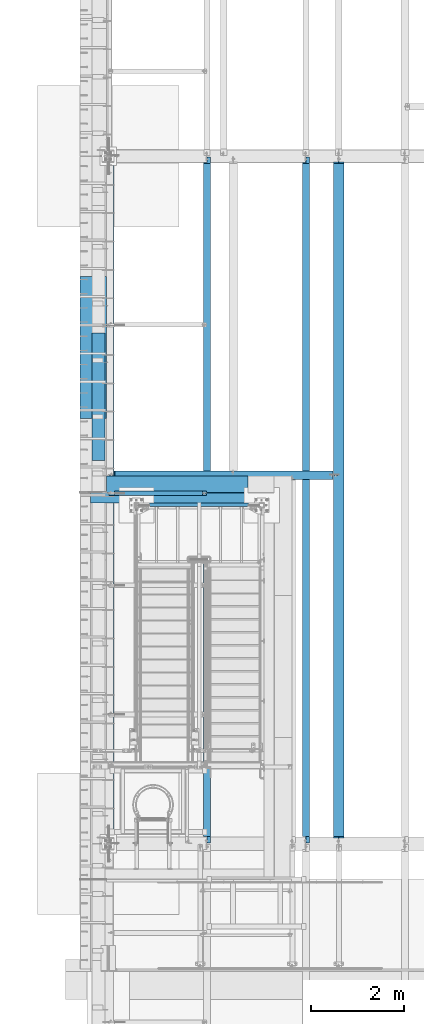
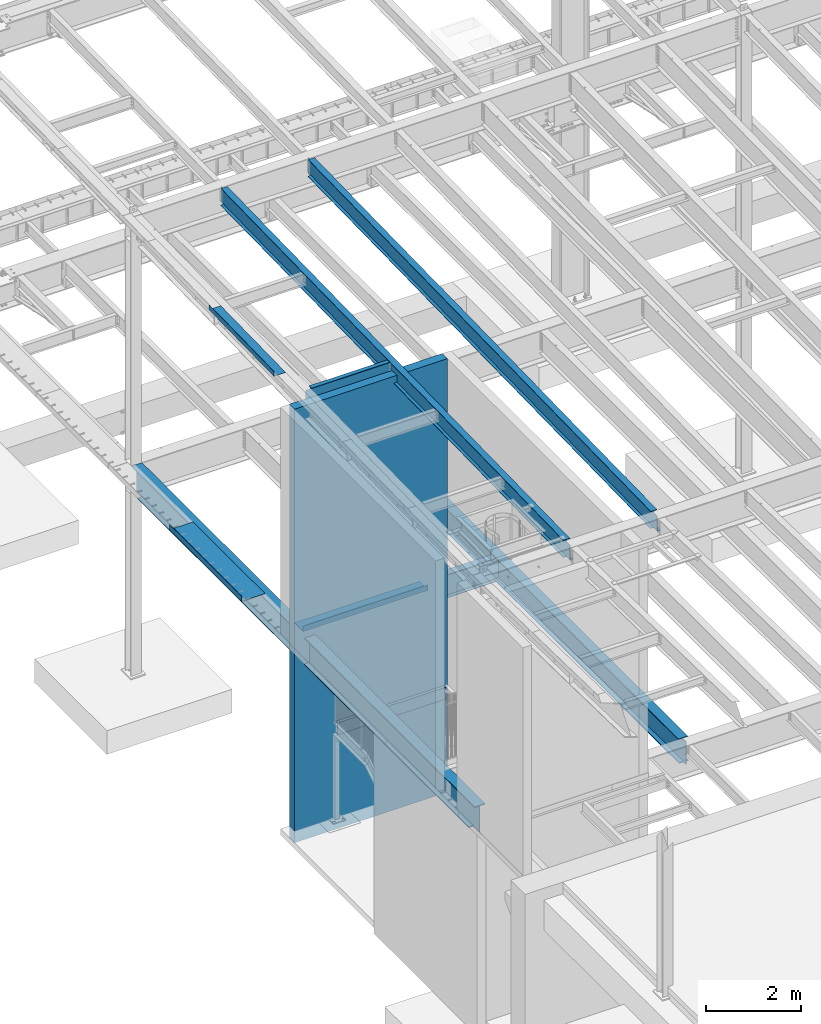
# One storey, part 1095 of 1763: 11 beams, 9 elements without a shape of their own.
"""IFC2X3 building model written with IfcOpenShell, lengths in millimetres."""

from ifc_helpers import new_model, si_unit, frame, origin_with_axes, place, context, subcontext, project, spatial, faceted_brep, material, type_object, element, aggregate, save


model = new_model("IFC2X3")

# Units and contexts
model_context = context("Model", 3, precision=1e-05, world=origin_with_axes())
body_context = subcontext(model_context, "Body", "Model", "MODEL_VIEW")
ifc_project = project(units=[si_unit("LENGTHUNIT", "METRE", prefix="MILLI"), si_unit("AREAUNIT", "SQUARE_METRE"), si_unit("VOLUMEUNIT", "CUBIC_METRE"), si_unit("MASSUNIT", "GRAM", prefix="KILO"), si_unit("TIMEUNIT", "SECOND"), si_unit("PLANEANGLEUNIT", "RADIAN"), si_unit("SOLIDANGLEUNIT", "STERADIAN"), si_unit("THERMODYNAMICTEMPERATUREUNIT", "DEGREE_CELSIUS"), si_unit("LUMINOUSINTENSITYUNIT", "LUMEN")], contexts=[model_context])

# Site, building, storey
site_placement = place(None, origin_with_axes())
site = spatial("IfcSite", under=ifc_project, at=site_placement, CompositionType="ELEMENT")
building_placement = place(site_placement, origin_with_axes())
building = spatial("IfcBuilding", under=site, at=building_placement, Name="Undefined", CompositionType="ELEMENT")
storey_placement = place(building_placement, origin_with_axes())
storey = spatial("IfcBuildingStorey", under=building, at=storey_placement, Name="Undefined", CompositionType="ELEMENT", Elevation=0.0)

# Assembly, beam
assembly_1_placement = place(storey_placement, origin_with_axes())
assembly_1 = element("IfcElementAssembly", 1, at=assembly_1_placement, inside=storey, Name="STRINGER", AssemblyPlace="NOTDEFINED", PredefinedType="RIGID_FRAME")
ifc_material_1 = material(Name="STEEL/A36")
beam_type_1 = type_object("IfcBeamType", Name="C12X20.7", PredefinedType="NOTDEFINED")
beam_1_placement = place(assembly_1_placement, frame((-84098.8372737317, 37312.6, 2630.48750002433), z_axis=(0.0, 0.0, 1.0), x_axis=(-1.0, 0.0, 0.0)))
beam_1 = element("IfcBeam", 2, at=beam_1_placement, type_object=beam_type_1, material=ifc_material_1, Name="STRINGER", ObjectType="C12X20.7", context=body_context, shape_type="Brep", body=[
    faceted_brep([(0.0, 38.1000000000004, -152.4), (0.0, 38.1000000000004, 152.4), (2641.60000000367, 38.0999999999985, 152.4), (2641.60000000367, 38.0999999999985, -152.4), (0.0, -38.1000000000004, 152.4), (2641.60000000367, -38.0999999999985, 152.4), (0.0, -38.1000000000004, 146.04746), (2641.60000000367, -38.0999999999985, 146.04746), (0.0, 30.1625000000004, 134.6749275), (2641.60000000367, 30.1624999999985, 134.6749275), (0.0, 30.1625000000004, -134.6749275), (2641.60000000367, 30.1624999999985, -134.6749275), (0.0, -38.1000000000004, -146.04746), (2641.60000000367, -38.0999999999985, -146.04746), (0.0, -38.1000000000004, -152.4), (2641.60000000367, -38.0999999999985, -152.4)], [[[0, 1, 2, 3]], [[1, 4, 5, 2]], [[4, 6, 7, 5]], [[6, 8, 9, 7]], [[8, 10, 11, 9]], [[10, 12, 13, 11]], [[12, 14, 15, 13]], [[14, 0, 3, 15]], [[5, 7, 9, 11, 13, 15, 3, 2]], [[14, 12, 10, 8, 6, 4, 1, 0]]]),
])
aggregate(assembly_1, [beam_1])

assembly_2_placement = place(storey_placement, origin_with_axes())
assembly_2 = element("IfcElementAssembly", 3, at=assembly_2_placement, inside=storey, Name="BEAM", AssemblyPlace="NOTDEFINED", PredefinedType="RIGID_FRAME")
beam_type_2 = type_object("IfcBeamType", PredefinedType="NOTDEFINED")
beam_2_placement = place(assembly_2_placement, frame((-85888.7435236983, 37934.9, 5199.0625), z_axis=(-1.0, 0.0, 0.0), x_axis=(0.0, -1.0, 0.0)))
beam_2 = element("IfcBeam", 4, at=beam_2_placement, type_object=beam_type_2, material=ifc_material_1, Name="BENT_PLATE", context=body_context, shape_type="Brep", body=[
    faceted_brep([(0.0, -4.76249999999982, -1524.0), (0.0, -4.76249999999982, 1524.0), (0.0, 4.76249999999982, 1524.0), (0.0, 4.76249999999982, -1524.0), (358.774987792975, 4.76249999999982, 1524.0), (358.774987792975, 4.76249999999982, -1524.0), (368.299987792969, -4.76249999999982, -1524.0), (368.299987792969, -4.76249999999982, 1524.0), (358.774987792975, 134.937496948242, 1524.0), (358.774987792975, 134.937496948242, -1524.0), (368.299987792969, 134.937496948242, 1524.0), (368.299987792969, 134.937496948242, -1524.0)], [[[0, 1, 2, 3]], [[3, 2, 4, 5]], [[1, 0, 6, 7]], [[5, 4, 8, 9]], [[4, 2, 1, 7, 10, 8]], [[7, 6, 11, 10]], [[6, 0, 3, 5, 9, 11]], [[10, 11, 9, 8]]]),
])

assembly_3_placement = place(storey_placement, origin_with_axes())
assembly_3 = element("IfcElementAssembly", 5, at=assembly_3_placement, inside=storey, Name="BEAM", AssemblyPlace="NOTDEFINED", PredefinedType="RIGID_FRAME")
beam_type_3 = type_object("IfcBeamType", PredefinedType="NOTDEFINED")
beam_3_placement = place(assembly_3_placement, frame((-87413.5372736984, 40693.9755, 5199.0625), z_axis=(0.0, -1.0, 0.0), x_axis=(-1.0, 0.0, 0.0)))
beam_3 = element("IfcBeam", 6, at=beam_3_placement, type_object=beam_type_3, material=ifc_material_1, Name="BENT_PLATE", context=body_context, shape_type="Brep", body=[
    faceted_brep([(0.0, -4.76249999999982, -1524.0), (0.0, -4.76249999999982, 1524.0), (0.0, 4.76249999999982, 1524.0), (0.0, 4.76249999999982, -1524.0), (571.5, 4.76249999999982, 1524.0), (571.5, 4.76249999999982, -1524.0), (561.975000000006, -4.76249999999982, -1524.0), (561.975000000006, -4.76249999999982, 1524.0), (571.5, -134.937496948242, 1524.0), (571.5, -134.937496948242, -1524.0), (561.975000000006, -134.937496948242, 1524.0), (561.975000000006, -134.937496948242, -1524.0)], [[[0, 1, 2, 3]], [[3, 2, 4, 5]], [[1, 0, 6, 7]], [[5, 4, 8, 9]], [[4, 2, 1, 7, 10, 8]], [[7, 6, 11, 10]], [[6, 0, 3, 5, 9, 11]], [[10, 11, 9, 8]]]),
])

assembly_4_placement = place(storey_placement, origin_with_axes())
assembly_4 = element("IfcElementAssembly", 7, at=assembly_4_placement, inside=storey, Name="BEAM", AssemblyPlace="NOTDEFINED", PredefinedType="RIGID_FRAME")
beam_type_4 = type_object("IfcBeamType", PredefinedType="NOTDEFINED")
beam_4_placement = place(assembly_4_placement, frame((-87438.9372736983, 39629.9999848266, 11492.2453307455), z_axis=(0.0, -0.999786037781472, -0.0206852279954809), x_axis=(-1.0, 0.0, 0.0)))
beam_4 = element("IfcBeam", 8, at=beam_4_placement, type_object=beam_type_4, material=ifc_material_1, Name="BENT_PLATE", context=body_context, shape_type="Brep", body=[
    faceted_brep([(2.91038304567337e-11, -3.17499999963729, -1371.60000000396), (-2.91038304567337e-11, -3.17500000036489, 1371.60000000395), (-2.91038304567337e-11, 3.17499999963184, 1371.60000000395), (2.91038304567337e-11, 3.17500000035943, -1371.60000000396), (285.75000000016, 3.17499999930078, 1371.59999999897), (285.750000000276, 3.17499999982283, -1371.59999999897), (279.400000000271, -3.1750000001648, -1371.59999999897), (279.400000000154, -3.17500000068321, 1371.59999999897), (285.750000000218, -123.824997298658, 1371.59999999895), (285.750000000218, -123.824997298212, -1371.59999999898), (279.400000000212, -123.824997298658, 1371.59999999895), (279.400000000212, -123.824997298212, -1371.59999999898)], [[[0, 1, 2, 3]], [[3, 2, 4, 5]], [[1, 0, 6, 7]], [[5, 4, 8, 9]], [[4, 2, 1, 7, 10, 8]], [[7, 6, 11, 10]], [[6, 0, 3, 5, 9, 11]], [[10, 11, 9, 8]]]),
])
aggregate(assembly_4, [beam_4])

assembly_5_placement = place(storey_placement, origin_with_axes())
assembly_5 = element("IfcElementAssembly", 9, at=assembly_5_placement, inside=storey, Name="BEAM", AssemblyPlace="NOTDEFINED", PredefinedType="RIGID_FRAME")
ifc_material_2 = material(Name="STEEL/A992")
beam_type_5 = type_object("IfcBeamType", Name="W18X35", PredefinedType="NOTDEFINED")
beam_5_placement = place(assembly_5_placement, frame((-83122.7515594126, 30027.4629676506, 11064.9232324289), z_axis=(0.0, -0.0206852279954837, 0.999786037781472), x_axis=(0.0, 0.999786037781472, 0.0206852279954825)))
beam_5 = element("IfcBeam", 10, at=beam_5_placement, type_object=beam_type_5, material=ifc_material_2, Name="BEAM", ObjectType="W18X35", context=body_context, shape_type="Brep", body=[
    faceted_brep([(161.234036217043, 4.26867060289806, -214.312499999869), (161.234036217025, 4.26882632687921, -225.424999999863), (10.5200655540102, 4.26881607816904, -225.424999999832), (10.7499793429743, 4.26866036980209, -214.312499999842), (161.234031325755, 76.1999999999971, -214.312499999867), (161.234031325748, 76.1999999999971, -225.424999999861), (161.234031013333, -3.96875, 180.714997672841), (161.234031013333, 3.96875, 180.714997672841), (160.267301090749, 3.96875, 175.854918154808), (160.267301090749, -3.96875, 175.854918154808), (157.514287190275, 3.96875, 171.734741686663), (157.514287190275, -3.96875, 171.734741686663), (153.394110722133, 3.96875, 168.981727786193), (153.394110722133, -3.96875, 168.981727786193), (148.534031204097, 3.96875, 168.014997863607), (148.534031204097, -3.96875, 168.014997863607), (18.6602033211384, 3.96875, 168.014997863631), (18.6602033211384, -3.96875, 168.014997863631), (10.7499793429743, -3.96875, -214.312499999842), (14757.8115434472, -3.96875, -214.312500002648), (14765.8531467846, -3.96875, 174.36500163611), (14641.5955948759, -3.96875, 174.365001636133), (14636.7355153579, -3.96875, 175.331731558719), (14632.6153388897, -3.96875, 178.084745459191), (14629.8623249892, -3.96875, 182.204921927336), (14628.8955950666, -3.96875, 187.065001445368), (14628.8955950666, -3.96875, 214.312499997053), (161.234030986467, -3.96875, 214.312499999809), (10.7499793429743, -76.1999999999971, -214.312499999842), (14757.8115434472, -76.1999999999971, -214.312500002648), (10.5200655540102, -76.1999999999971, -225.424999999832), (14757.5816296582, -76.1999999999971, -225.425000002639), (14641.5955921487, 4.26882640406257, -214.312500002627), (14641.5955921487, 4.26867068048159, -225.425000002617), (14641.5955830855, 76.1999999999971, -225.425000002617), (14641.5955830855, 76.1999999999971, -214.312500002628), (14757.8115434472, 4.26884104704368, -214.312500002648), (14757.5816296582, 4.26868529446074, -225.425000002639), (14757.8115434472, 3.96875, -214.312500002648), (14765.8531467846, 3.96875, 174.36500163611), (14641.5955948759, 3.96875, 174.365001636133), (14636.7355153579, 3.96875, 175.331731558719), (14632.6153388897, 3.96875, 178.084745459191), (14629.8623249892, 3.96875, 182.204921927336), (14628.8955950666, 3.96875, 187.065001445368), (14628.8955950666, -76.1999999999971, 225.424999997045), (14628.8955950666, -76.1999999999971, 214.312499997053), (14628.8955950666, 3.96875, 214.312499997053), (14628.8955950666, 76.1999999999971, 214.312499997053), (14628.8955950666, 76.1999999999971, 225.424999997045), (161.234030986467, 3.96875, 214.312499999809), (161.234030986467, 76.1999999999971, 214.312499999809), (161.23403098647, 76.1999999999971, 225.424999999799), (161.23403098647, -76.1999999999971, 225.424999999799), (161.234030986467, -76.1999999999971, 214.312499999809), (10.7499793429743, 3.96875, -214.312499999842)], [[[0, 1, 2, 3]], [[4, 5, 1, 0]], [[6, 7, 8, 9]], [[9, 8, 10, 11]], [[11, 10, 12, 13]], [[13, 12, 14, 15]], [[15, 14, 16, 17]], [[9, 11, 13, 15, 17, 18, 19, 20, 21, 22, 23, 24, 25, 26, 27, 6]], [[18, 28, 29, 19]], [[28, 30, 31, 29]], [[32, 33, 34, 35]], [[36, 37, 33, 32]], [[38, 39, 20, 19, 29, 31, 37, 36]], [[20, 39, 40, 21]], [[21, 40, 41, 22]], [[22, 41, 42, 23]], [[23, 42, 43, 24]], [[24, 43, 44, 25]], [[45, 46, 26, 25, 44, 47, 48, 49]], [[48, 47, 50, 51]], [[49, 48, 51, 52]], [[45, 49, 52, 53]], [[46, 45, 53, 54]], [[26, 46, 54, 27]], [[53, 52, 51, 50, 7, 6, 27, 54]], [[47, 44, 43, 42, 41, 40, 39, 38, 55, 16, 14, 12, 10, 8, 7, 50]], [[30, 28, 18, 17, 16, 55, 3, 2]], [[34, 33, 37, 31, 30, 2, 1, 5]], [[35, 34, 5, 4]], [[55, 38, 36, 32, 35, 4, 0, 3]]]),
])
aggregate(assembly_5, [beam_5])

assembly_6_placement = place(storey_placement, origin_with_axes())
assembly_6 = element("IfcElementAssembly", 11, at=assembly_6_placement, inside=storey, Name="BEAM", AssemblyPlace="NOTDEFINED", PredefinedType="RIGID_FRAME")
beam_6_placement = place(assembly_6_placement, frame((-85249.0944165555, 30027.4629676506, 11064.9232324289), z_axis=(0.0, -0.0206852279954837, 0.999786037781472), x_axis=(0.0, 0.999786037781472, 0.0206852279954825)))
beam_6 = element("IfcBeam", 12, at=beam_6_placement, type_object=beam_type_5, material=ifc_material_2, Name="BEAM", ObjectType="W18X35", context=body_context, shape_type="Brep", body=[
    faceted_brep([(161.234036217043, 4.26867060289806, -214.312499999869), (161.234036217025, 4.26882632687921, -225.424999999863), (10.5200655540102, 4.26881607816904, -225.424999999832), (10.7499793429743, 4.26866036980209, -214.312499999842), (161.234031325755, 76.1999999999971, -214.312499999867), (161.234031325748, 76.1999999999971, -225.424999999861), (161.234031013333, -3.96875, 180.714997672841), (161.234031013333, 3.96875, 180.714997672841), (160.267301090749, 3.96875, 175.854918154808), (160.267301090749, -3.96875, 175.854918154808), (157.514287190275, 3.96875, 171.734741686663), (157.514287190275, -3.96875, 171.734741686663), (153.394110722133, 3.96875, 168.981727786193), (153.394110722133, -3.96875, 168.981727786193), (148.534031204097, 3.96875, 168.014997863607), (148.534031204097, -3.96875, 168.014997863607), (18.6602033211384, 3.96875, 168.014997863631), (18.6602033211384, -3.96875, 168.014997863631), (10.7499793429743, -3.96875, -214.312499999842), (14757.8115434472, -3.96875, -214.312500002648), (14765.8531467846, -3.96875, 174.36500163611), (14641.5955948759, -3.96875, 174.365001636133), (14636.7355153579, -3.96875, 175.331731558719), (14632.6153388897, -3.96875, 178.084745459191), (14629.8623249892, -3.96875, 182.204921927336), (14628.8955950666, -3.96875, 187.065001445368), (14628.8955950666, -3.96875, 214.312499997053), (161.234030986467, -3.96875, 214.312499999809), (10.7499793429743, -76.1999999999971, -214.312499999842), (14757.8115434472, -76.1999999999971, -214.312500002648), (10.5200655540102, -76.1999999999971, -225.424999999832), (14757.5816296582, -76.1999999999971, -225.425000002639), (14641.5955921487, 4.26882640406257, -214.312500002627), (14641.5955921487, 4.26867068048159, -225.425000002617), (14641.5955830855, 76.1999999999971, -225.425000002617), (14641.5955830855, 76.1999999999971, -214.312500002628), (14757.8115434472, 4.26884104704368, -214.312500002648), (14757.5816296582, 4.26868529446074, -225.425000002639), (14757.8115434472, 3.96875, -214.312500002648), (14765.8531467846, 3.96875, 174.36500163611), (14641.5955948759, 3.96875, 174.365001636133), (14636.7355153579, 3.96875, 175.331731558719), (14632.6153388897, 3.96875, 178.084745459191), (14629.8623249892, 3.96875, 182.204921927336), (14628.8955950666, 3.96875, 187.065001445368), (14628.8955950666, -76.1999999999971, 225.424999997045), (14628.8955950666, -76.1999999999971, 214.312499997053), (14628.8955950666, 3.96875, 214.312499997053), (14628.8955950666, 76.1999999999971, 214.312499997053), (14628.8955950666, 76.1999999999971, 225.424999997045), (161.234030986467, 3.96875, 214.312499999809), (161.234030986467, 76.1999999999971, 214.312499999809), (161.23403098647, 76.1999999999971, 225.424999999799), (161.23403098647, -76.1999999999971, 225.424999999799), (161.234030986467, -76.1999999999971, 214.312499999809), (10.7499793429743, 3.96875, -214.312499999842)], [[[0, 1, 2, 3]], [[4, 5, 1, 0]], [[6, 7, 8, 9]], [[9, 8, 10, 11]], [[11, 10, 12, 13]], [[13, 12, 14, 15]], [[15, 14, 16, 17]], [[9, 11, 13, 15, 17, 18, 19, 20, 21, 22, 23, 24, 25, 26, 27, 6]], [[18, 28, 29, 19]], [[28, 30, 31, 29]], [[32, 33, 34, 35]], [[36, 37, 33, 32]], [[38, 39, 20, 19, 29, 31, 37, 36]], [[20, 39, 40, 21]], [[21, 40, 41, 22]], [[22, 41, 42, 23]], [[23, 42, 43, 24]], [[24, 43, 44, 25]], [[45, 46, 26, 25, 44, 47, 48, 49]], [[48, 47, 50, 51]], [[49, 48, 51, 52]], [[45, 49, 52, 53]], [[46, 45, 53, 54]], [[26, 46, 54, 27]], [[53, 52, 51, 50, 7, 6, 27, 54]], [[47, 44, 43, 42, 41, 40, 39, 38, 55, 16, 14, 12, 10, 8, 7, 50]], [[30, 28, 18, 17, 16, 55, 3, 2]], [[34, 33, 37, 31, 30, 2, 1, 5]], [[35, 34, 5, 4]], [[55, 38, 36, 32, 35, 4, 0, 3]]]),
])
aggregate(assembly_6, [beam_6])

assembly_7_placement = place(storey_placement, origin_with_axes())
assembly_7 = element("IfcElementAssembly", 13, at=assembly_7_placement, inside=storey, Name="BEAM", AssemblyPlace="NOTDEFINED", PredefinedType="RIGID_FRAME")
beam_type_6 = type_object("IfcBeamType", Name="W12X22", PredefinedType="NOTDEFINED")
beam_7_placement = place(assembly_7_placement, frame((-87375.4372736983, 37560.25, 11290.6722385647), z_axis=(0.0, 0.0, 1.0), x_axis=(1.0, 0.0, 0.0)))
beam_7 = element("IfcBeam", 14, at=beam_7_placement, type_object=beam_type_6, material=ifc_material_2, Name="BEAM", ObjectType="W12X22", context=body_context, shape_type="Brep", body=[
    faceted_brep([(18.2562499999913, -3.17499999999927, -144.4625), (18.2562499999913, -50.7999999999993, -144.4625), (2109.67410714286, -50.7999999999993, -144.4625), (2109.67410714286, -3.17499999999927, -144.4625), (18.2562499999913, -50.7999999999993, -155.575000000001), (2109.67410714286, -50.7999999999993, -155.575000000001), (2109.67410714286, 3.17499999999927, -144.4625), (2109.67410714286, 50.7999999999993, -144.4625), (132.556249999994, 50.7999999999993, -144.4625), (132.556249999994, 3.17575008238782, -144.4625), (2033.47410714286, -50.7999999999993, 155.575000000001), (2033.47410714286, -50.7999999999993, 144.4625), (2033.47410714286, -3.17499999999927, 144.4625), (2033.47410714286, -3.17499999999927, 136.265001487105), (2033.47410714286, 3.17499999999927, 136.265001487105), (2033.47410714286, 3.17499999999927, 144.4625), (2033.47410714286, 50.7999999999993, 144.4625), (2033.47410714286, 50.7999999999993, 155.575000000001), (2034.44083706544, -3.17499999999927, 131.404921969059), (2034.44083706544, 3.17499999999927, 131.404921969059), (2037.19385096592, -3.17499999999927, 127.284745500905), (2037.19385096592, 3.17499999999927, 127.284745500905), (2041.31402743408, -3.17499999999927, 124.531731600428), (2041.31402743408, 3.17499999999927, 124.531731600428), (2046.17410695212, -3.17499999999927, 123.56500167784), (2046.17410695212, 3.17499999999927, 123.56500167784), (2109.67410714286, -3.17499999999927, 123.56500167784), (2109.67410714286, 3.17499999999927, 123.56500167784), (2109.67410714286, 50.7999999999993, -155.575000000001), (132.556249999994, 50.7999999999993, -155.575000000001), (132.556249999994, 3.17575008238782, -155.575000000001), (18.2562499999913, 3.17575008238782, -155.575000000001), (18.2562499999913, 3.17499999999927, -144.4625), (124.716329708754, -3.17499999999927, 105.741729925645), (124.716329708754, 3.17500736736474, 105.741729925645), (119.856250190714, 3.1750086254724, 104.775000003057), (119.856250190714, -3.17499999999927, 104.775000003057), (128.836506176915, -3.17499999999927, 108.494743826122), (128.836506176915, 3.17500378457771, 108.494743826122), (131.589520077396, -3.17499999999927, 112.614920294276), (131.589520077396, 3.17499842256075, 112.614920294276), (132.55624999998, -3.17499999999927, 117.474999812322), (132.55624999998, 3.17499209762536, 117.474999812322), (18.2562499999913, 3.17499999999927, -137.353076309833), (18.2562499999913, 3.17499999999927, 104.775000003057), (132.55624999998, 3.17499999999927, 144.4625), (132.55624999998, 50.7999999999993, 144.4625), (132.55624999998, 50.7999999999993, 155.575000000001), (132.55624999998, -50.7999999999993, 155.575000000001), (132.55624999998, -50.7999999999993, 144.4625), (132.55624999998, -3.17499999999927, 144.4625), (18.2562499999913, -3.17499999999927, 104.775000003057)], [[[0, 1, 2, 3]], [[1, 4, 5, 2]], [[6, 7, 8, 9]], [[10, 11, 12, 13, 14, 15, 16, 17]], [[18, 19, 14, 13]], [[20, 21, 19, 18]], [[22, 23, 21, 20]], [[24, 25, 23, 22]], [[26, 27, 25, 24]], [[3, 2, 5, 28, 7, 6, 27, 26]], [[7, 28, 29, 8]], [[8, 29, 30, 9]], [[28, 5, 4, 31, 30, 29]], [[9, 30, 31, 32]], [[33, 34, 35, 36]], [[37, 38, 34, 33]], [[39, 40, 38, 37]], [[41, 42, 40, 39]], [[15, 14, 19, 21, 23, 25, 27, 6, 9, 32, 43, 44, 35, 34, 38, 40, 42, 45]], [[16, 15, 45, 46]], [[17, 16, 46, 47]], [[10, 17, 47, 48]], [[11, 10, 48, 49]], [[12, 11, 49, 50]], [[48, 47, 46, 45, 42, 41, 50, 49]], [[39, 37, 33, 36, 51, 0, 3, 26, 24, 22, 20, 18, 13, 12, 50, 41]], [[43, 32, 31, 4, 1, 0, 51, 44]], [[36, 35, 44, 51]]]),
])
aggregate(assembly_7, [beam_7])

# Beam
beam_type_7 = type_object("IfcBeamType", Name="W24X55", PredefinedType="NOTDEFINED")
beam_8_placement = place(assembly_2_placement, frame((-87375.4372736983, 37947.6, 4894.2625), z_axis=(0.0, 0.0, 1.0), x_axis=(1.0, 0.0, 0.0)))
beam_8 = element("IfcBeam", 15, at=beam_8_placement, type_object=beam_type_7, material=ifc_material_2, Name="BEAM", ObjectType="W24X55", context=body_context, shape_type="Brep", body=[
    faceted_brep([(19.84375, -5.06289274062146, -287.3375), (19.84375, -5.06217950861901, -300.0375), (121.443785019117, -5.06214201812691, -300.0375), (121.443785019292, -5.06285525016574, -287.3375), (121.443815955325, -88.9000000000015, -287.3375), (121.443815955325, -88.9000000000015, -300.0375), (121.443751839222, 88.9000000000015, -300.0375), (121.443751839222, 88.9000000000015, -287.3375), (4834.46666666666, 88.9000000000015, -287.3375), (4834.46666666666, 88.9000000000015, -300.0375), (121.44378277479, 5.06285495873453, -300.0375), (121.443782774979, 5.0621417266957, -287.3375), (19.84375, 5.06281746905006, -300.0375), (19.84375, 5.06210423704761, -287.3375), (19.84375, 4.76249999999709, -287.3375), (4834.46666666666, 4.76249999999709, -287.3375), (4942.41666666666, -4.76249999999709, 268.027501678467), (4942.41666666666, 4.76249999999709, 268.027501678467), (4847.16666647593, 4.76249999999709, 268.027501678467), (4847.16666647593, -4.76249999999709, 268.027501678467), (4842.30658695789, 4.76249999999709, 268.994231601055), (4842.30658695789, -4.76249999999709, 268.994231601055), (4838.18641048972, 4.76249999999709, 271.747245501533), (4838.18641048972, -4.76249999999709, 271.747245501533), (4835.43339658924, 4.76249999999709, 275.867421969687), (4835.43339658924, -4.76249999999709, 275.867421969687), (4834.46666666666, 4.76249999999709, 280.727501487732), (4834.46666666666, -4.76249999999709, 280.727501487732), (4834.46666666666, -88.9000000000015, 300.0375), (4834.46666666666, -88.9000000000015, 287.3375), (4834.46666666666, -4.76249999999709, 287.3375), (4834.46666666666, 4.76249999999709, 287.3375), (4834.46666666666, 88.9000000000015, 287.3375), (4834.46666666666, 88.9000000000015, 300.0375), (146.843749999985, 4.76249999999709, 287.3375), (146.843749999985, 88.9000000000015, 287.3375), (146.843749999985, 88.9000000000015, 300.0375), (146.843749999985, -88.9000000000015, 300.0375), (146.843749999985, -88.9000000000015, 287.3375), (146.843749999985, -4.76249999999709, 287.3375), (146.843749999985, 4.76249999999709, 274.377501487732), (146.843749999985, -4.76249999999709, 274.377501487732), (145.877020077402, 4.76249999999709, 269.517421969686), (145.877020077402, -4.76249999999709, 269.517421969686), (143.12400617692, 4.76249999999709, 265.397245501533), (143.12400617692, -4.76249999999709, 265.397245501533), (139.003829708759, 4.76249999999709, 262.644231601054), (139.003829708759, -4.76249999999709, 262.644231601054), (134.14375019072, 4.76249999999709, 261.677501678467), (134.14375019072, -4.76249999999709, 261.677501678467), (19.84375, 4.76249999999709, 261.677501678467), (19.84375, -4.76249999999709, 261.677501678467), (19.84375, -4.76249999999709, -287.3375), (4834.46666666666, -4.76249999999709, -287.3375), (4834.46666666666, -4.76249999999709, -284.422499809265), (4835.43339658924, -4.76249999999709, -279.562420291219), (4838.18641048972, -4.76249999999709, -275.442243823066), (4842.30658695789, -4.76249999999709, -272.689229922587), (4847.16666647593, -4.76249999999709, -271.7225), (4942.41666666666, -4.76249999999709, -271.7225), (4942.41666666666, 4.76249999999709, -271.7225), (4842.30658695789, 4.76249999999709, -272.689229922587), (4838.18641048972, 4.76249999999709, -275.442243823066), (4835.43339658924, 4.76249999999709, -279.562420291219), (4834.46666666666, 4.76249999999709, -284.422499809265), (4847.16666647593, 4.76249999999709, -271.7225), (4834.46666666666, -88.9000000000015, -287.3375), (4834.46666666666, -88.9000000000015, -300.0375)], [[[0, 1, 2, 3]], [[4, 3, 2, 5]], [[6, 7, 8, 9]], [[7, 6, 10, 11]], [[11, 10, 12, 13]], [[7, 11, 13, 14, 15, 8]], [[16, 17, 18, 19]], [[19, 18, 20, 21]], [[21, 20, 22, 23]], [[23, 22, 24, 25]], [[25, 24, 26, 27]], [[28, 29, 30, 27, 26, 31, 32, 33]], [[32, 31, 34, 35]], [[33, 32, 35, 36]], [[28, 33, 36, 37]], [[29, 28, 37, 38]], [[30, 29, 38, 39]], [[37, 36, 35, 34, 40, 41, 39, 38]], [[41, 40, 42, 43]], [[43, 42, 44, 45]], [[45, 44, 46, 47]], [[47, 46, 48, 49]], [[49, 48, 50, 51]], [[16, 19, 21, 23, 25, 27, 30, 39, 41, 43, 45, 47, 49, 51, 52, 53, 54, 55, 56, 57, 58, 59]], [[17, 16, 59, 60]], [[61, 62, 63, 64, 15, 14, 50, 48, 46, 44, 42, 40, 34, 31, 26, 24, 22, 20, 18, 17, 60, 65]], [[59, 58, 65, 60]], [[57, 61, 65, 58]], [[56, 62, 61, 57]], [[55, 63, 62, 56]], [[54, 64, 63, 55]], [[53, 66, 67, 9, 8, 15, 64, 54]], [[67, 66, 4, 5]], [[1, 12, 10, 6, 9, 67, 5, 2]], [[52, 51, 50, 14, 13, 12, 1, 0]], [[66, 53, 52, 0, 3, 4]]]),
])

aggregate(assembly_2, [beam_2, beam_8])

# Assembly, beam
assembly_8_placement = place(storey_placement, origin_with_axes())
assembly_8 = element("IfcElementAssembly", 16, at=assembly_8_placement, inside=storey, Name="WALL", AssemblyPlace="NOTDEFINED", PredefinedType="REINFORCEMENT_UNIT")
ifc_material_3 = material(Name="CONCRETE/5000")
beam_type_8 = type_object("IfcBeamType", PredefinedType="NOTDEFINED")
beam_9_placement = place(assembly_8_placement, frame((-87750.0872736983, 37458.65, 5588.0), z_axis=(0.0, 1.0, 0.0), x_axis=(1.0, 0.0, 0.0)))
beam_9 = element("IfcBeam", 17, at=beam_9_placement, type_object=beam_type_8, material=ifc_material_3, Name="WALL", context=body_context, shape_type="Brep", body=[
    faceted_brep([(0.0, 5588.0, -107.949999999997), (0.0, 5588.0, 107.949999999997), (3727.45, 5588.0, 107.949999999997), (3727.45, 5588.0, -107.949999999997), (0.0, -5588.0, 107.949999999997), (3727.45, -5588.0, 107.949999999997), (0.0, -5588.0, -107.949999999997), (3727.45, -5588.0, -107.949999999997)], [[[0, 1, 2, 3]], [[1, 4, 5, 2]], [[4, 6, 7, 5]], [[6, 0, 3, 7]], [[5, 7, 3, 2]], [[6, 4, 1, 0]]]),
])
aggregate(assembly_8, [beam_9])

# Beam
beam_type_9 = type_object("IfcBeamType", Name="W27X114", PredefinedType="NOTDEFINED")
beam_10_placement = place(assembly_3_placement, frame((-87375.4372736983, 30022.8, 4848.225), z_axis=(0.0, 0.0, 1.0), x_axis=(0.0, 1.0, 0.0)))
beam_10 = element("IfcBeam", 18, at=beam_10_placement, type_object=beam_type_9, material=ifc_material_2, Name="BEAM", ObjectType="W27X114", context=body_context, shape_type="Brep", body=[
    faceted_brep([(14384.3374461955, 7.44399065570906, -322.2625), (14384.3374461957, 7.44350345213024, -346.075), (14384.33740004, 128.587499999994, -346.075), (14384.33740004, 128.587499999994, -322.2625), (14638.3375, 7.44408742948144, -322.2625), (14638.3375, 7.44360022572801, -346.075), (398.462501906117, 128.587499999994, -322.2625), (398.462501906117, 128.587499999994, -346.075), (398.462548060696, 7.44399051558867, -346.075), (398.46254806087, 7.44350331200985, -322.2625), (144.462500000001, 7.44389374199091, -346.075), (144.462500000001, 7.44340653823747, -322.2625), (144.462500000001, -7.14375000000291, -322.2625), (144.462500000001, -7.14375000000291, 322.2625), (144.462500000001, -128.587499999994, 322.2625), (144.462500000001, -128.587499999994, 346.075), (144.462500000001, 128.587499999994, 346.075), (144.462500000001, 128.587499999994, 322.2625), (144.462500000001, 7.14375000000291, 322.2625), (144.462500000001, 7.14375000000291, -322.2625), (144.462500000001, -7.44360022523324, -346.075), (144.462500000001, -7.44408742898668, -322.2625), (398.462553804813, -7.44350345163548, -346.075), (398.462553804988, -7.44399065521429, -322.2625), (398.462599960465, -128.587499999994, -322.2625), (398.462599960465, -128.587499999994, -346.075), (14384.3374980992, -128.587499999994, -346.075), (14384.3374980992, -128.587499999994, -322.2625), (14384.3374519442, -7.44399051413347, -346.075), (14384.337451944, -7.44350331055466, -322.2625), (14638.3375, -7.44340653678228, -322.2625), (14638.3375, -7.44389374053571, -346.075), (14638.3375, -7.14375000000291, -322.2625), (14638.3375, -7.14375000000291, 322.2625), (14638.3375, -128.587499999994, 322.2625), (14638.3375, -128.587499999994, 346.075), (14638.3375, 128.587499999994, 346.075), (14638.3375, 128.587499999994, 322.2625), (14638.3375, 7.14375000000291, 322.2625), (14638.3375, 7.14375000000291, -322.2625)], [[[0, 1, 2, 3]], [[4, 5, 1, 0]], [[6, 7, 8, 9]], [[9, 8, 10, 11]], [[12, 13, 14, 15, 16, 17, 18, 19, 11, 10, 20, 21]], [[21, 20, 22, 23]], [[24, 23, 22, 25]], [[24, 25, 26, 27]], [[27, 26, 28, 29]], [[30, 29, 28, 31]], [[32, 12, 21, 23, 24, 27, 29, 30]], [[13, 12, 32, 33]], [[14, 13, 33, 34]], [[15, 14, 34, 35]], [[16, 15, 35, 36]], [[17, 16, 36, 37]], [[18, 17, 37, 38]], [[19, 18, 38, 39]], [[3, 6, 9, 11, 19, 39, 4, 0]], [[7, 6, 3, 2]], [[31, 28, 26, 25, 22, 20, 10, 8, 7, 2, 1, 5]], [[39, 38, 37, 36, 35, 34, 33, 32, 30, 31, 5, 4]]]),
])

aggregate(assembly_3, [beam_3, beam_10])

# Assembly, beam
assembly_9_placement = place(storey_placement, origin_with_axes())
assembly_9 = element("IfcElementAssembly", 19, at=assembly_9_placement, inside=storey, Name="BEAM", AssemblyPlace="NOTDEFINED", PredefinedType="RIGID_FRAME")
beam_type_10 = type_object("IfcBeamType", Name="W24X84", PredefinedType="NOTDEFINED")
beam_11_placement = place(assembly_9_placement, frame((-82413.9706070317, 30022.8, 4887.9125), z_axis=(0.0, 0.0, 1.0), x_axis=(0.0, 1.0, 0.0)))
beam_11 = element("IfcBeam", 20, at=beam_11_placement, type_object=beam_type_10, material=ifc_material_2, Name="BEAM", ObjectType="W24X84", context=body_context, shape_type="Brep", body=[
    faceted_brep([(19.8437500000036, -6.65018652749131, -287.3375), (19.8437500000036, -6.64983564552676, -306.3875), (121.44376406493, -6.64982304748264, -306.3875), (121.443764064999, -6.65017392941809, -287.3375), (121.443777413209, -114.300000000003, -287.3375), (121.443777413209, -114.300000000003, -306.3875), (159.543750000004, -6.35000000000582, 287.077501487732), (159.543750000004, 6.35000000000582, 287.077501487732), (158.577020077417, 6.35000000000582, 282.217421969686), (158.577020077417, -6.35000000000582, 282.217421969686), (155.824006176939, 6.35000000000582, 278.097245501533), (155.824006176939, -6.35000000000582, 278.097245501533), (151.703829708786, 6.35000000000582, 275.344231601054), (151.703829708786, -6.35000000000582, 275.344231601054), (146.843750190739, 6.35000000000582, 274.377501678467), (146.843750190739, -6.35000000000582, 274.377501678467), (19.8437500000036, 6.35000000000582, 274.377501678467), (19.8437500000036, -6.35000000000582, 274.377501678467), (19.8437500000036, -6.35000000000582, -287.3375), (14762.95625, -6.35000000000582, -287.3375), (14762.95625, -6.35000000000582, 274.377501678467), (14635.9562498093, -6.35000000000582, 274.377501678467), (14631.0961702912, -6.35000000000582, 275.344231601054), (14626.9759938231, -6.35000000000582, 278.097245501533), (14624.2229799226, -6.35000000000582, 282.217421969686), (14623.25625, -6.35000000000582, 287.077501487732), (14623.25625, -6.35000000000582, 287.3375), (159.543750000004, -6.35000000000582, 287.3375), (14762.95625, 6.35000000000582, 274.377501678467), (14635.9562498093, 6.35000000000582, 274.377501678467), (14631.0961702912, 6.35000000000582, 275.344231601054), (14626.9759938231, 6.35000000000582, 278.097245501533), (14624.2229799226, 6.35000000000582, 282.217421969686), (14623.25625, 6.35000000000582, 287.077501487732), (14623.25625, -114.300000000003, 306.3875), (14623.25625, -114.300000000003, 287.3375), (14623.25625, 6.35000000000582, 287.3375), (14623.25625, 114.300000000003, 287.3375), (14623.25625, 114.300000000003, 306.3875), (159.543750000004, 6.35000000000582, 287.3375), (159.543750000004, 114.300000000003, 287.3375), (159.543750000004, 114.300000000003, 306.3875), (159.543750000004, -114.300000000003, 306.3875), (159.543750000004, -114.300000000003, 287.3375), (14762.95625, 6.35000000000582, -287.3375), (19.8437500000036, 6.35000000000582, -287.3375), (14762.95625, 6.65018652763683, -287.3375), (14661.3562359333, 6.6501739295345, -287.3375), (14661.356222585, 114.300000000003, -287.3375), (121.443750621645, 114.300000000003, -287.3375), (121.443763969772, 6.6498230065481, -287.3375), (19.8437500000036, 6.64981040808198, -287.3375), (121.443763969703, 6.65017388848355, -306.3875), (19.8437500000036, 6.65016129003197, -306.3875), (121.443750621645, 114.300000000003, -306.3875), (14661.356222585, 114.300000000003, -306.3875), (14661.3562359333, 6.64982304759906, -306.3875), (14762.95625, 6.64983564568684, -306.3875), (14762.95625, -6.64981040751445, -287.3375), (14762.95625, -6.65016128946445, -306.3875), (14661.3562360316, -6.64982300561678, -287.3375), (14661.3562360316, -6.65017388755223, -306.3875), (14661.3562493796, -114.300000000003, -287.3375), (14661.3562493796, -114.300000000003, -306.3875)], [[[0, 1, 2, 3]], [[4, 3, 2, 5]], [[6, 7, 8, 9]], [[9, 8, 10, 11]], [[11, 10, 12, 13]], [[13, 12, 14, 15]], [[15, 14, 16, 17]], [[9, 11, 13, 15, 17, 18, 19, 20, 21, 22, 23, 24, 25, 26, 27, 6]], [[20, 28, 29, 21]], [[21, 29, 30, 22]], [[22, 30, 31, 23]], [[23, 31, 32, 24]], [[24, 32, 33, 25]], [[34, 35, 26, 25, 33, 36, 37, 38]], [[37, 36, 39, 40]], [[38, 37, 40, 41]], [[34, 38, 41, 42]], [[35, 34, 42, 43]], [[26, 35, 43, 27]], [[42, 41, 40, 39, 7, 6, 27, 43]], [[36, 33, 32, 31, 30, 29, 28, 44, 45, 16, 14, 12, 10, 8, 7, 39]], [[45, 44, 46, 47, 48, 49, 50, 51]], [[50, 52, 53, 51]], [[49, 54, 52, 50]], [[48, 55, 54, 49]], [[47, 56, 55, 48]], [[46, 57, 56, 47]], [[44, 28, 20, 19, 58, 59, 57, 46]], [[58, 60, 61, 59]], [[62, 63, 61, 60]], [[63, 62, 4, 5]], [[1, 53, 52, 54, 55, 56, 57, 59, 61, 63, 5, 2]], [[18, 17, 16, 45, 51, 53, 1, 0]], [[62, 60, 58, 19, 18, 0, 3, 4]]]),
])
aggregate(assembly_9, [beam_11])

save(model, "model.ifc")
